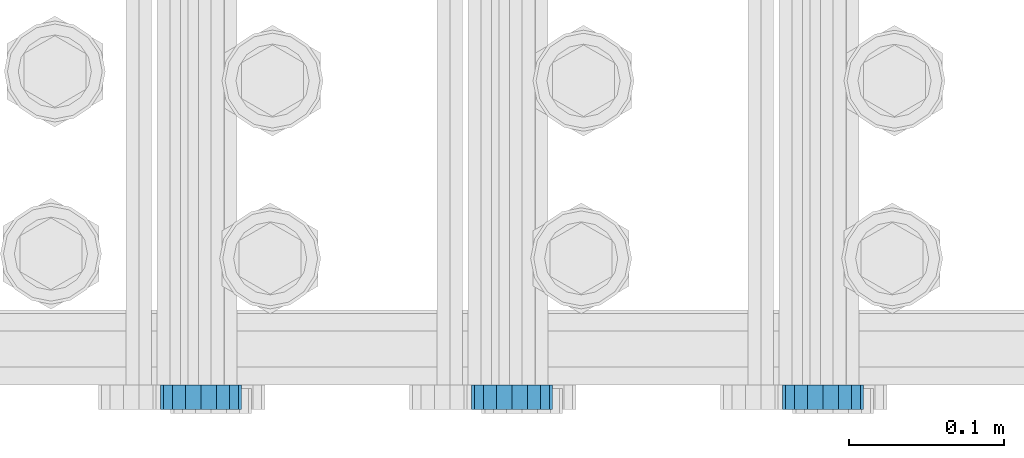
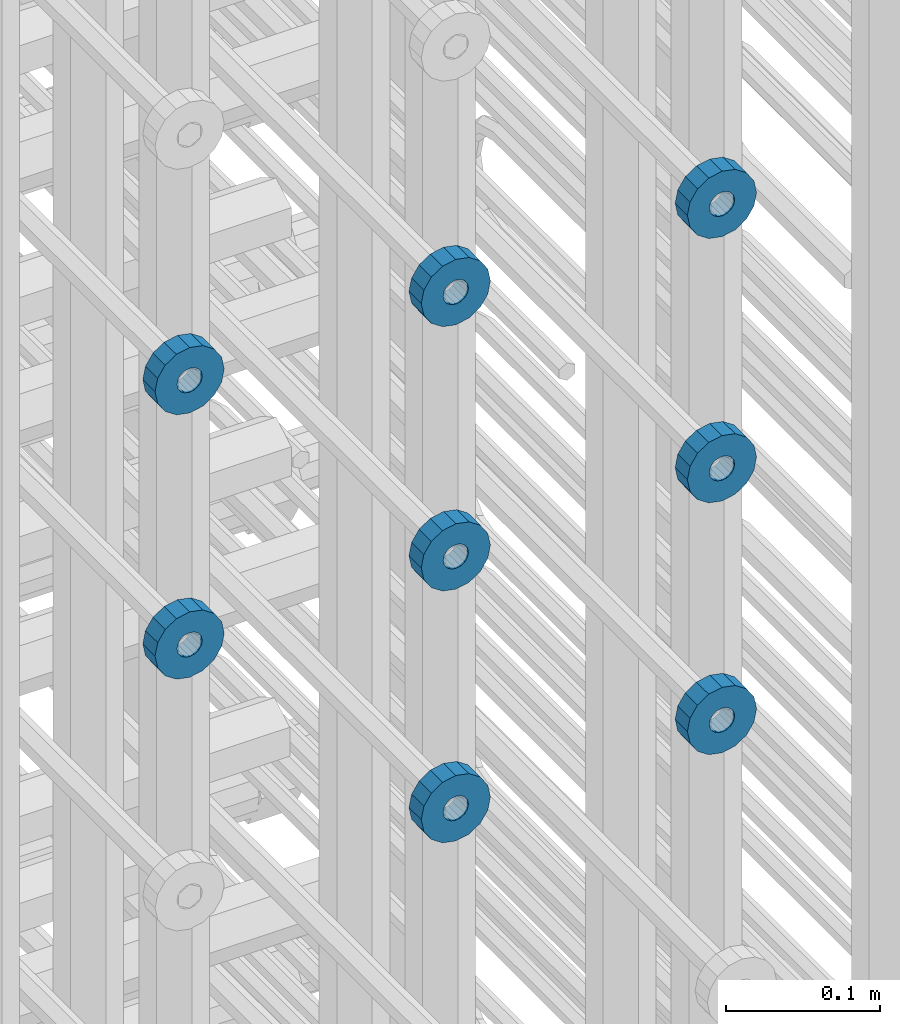
# One storey, part 124 of 177: 8 beams.
"""IFC2X3 building model written with IfcOpenShell, lengths in millimetres."""

from ifc_helpers import new_model, si_unit, frame, origin_with_axes, place, context, subcontext, project, spatial, faceted_brep, material, type_object, element, save


model = new_model("IFC2X3")

# Units and contexts
model_context_1 = context("Model", 3, precision=1e-05, world=origin_with_axes())
model_context_2 = context("Model", 3, precision=1e-05, world=origin_with_axes())
body_context = subcontext(model_context_2, "Body", "Model", "MODEL_VIEW")
ifc_project = project(units=[si_unit("LENGTHUNIT", "METRE", prefix="MILLI"), si_unit("AREAUNIT", "SQUARE_METRE"), si_unit("VOLUMEUNIT", "CUBIC_METRE"), si_unit("MASSUNIT", "GRAM", prefix="KILO"), si_unit("TIMEUNIT", "SECOND"), si_unit("PLANEANGLEUNIT", "RADIAN"), si_unit("SOLIDANGLEUNIT", "STERADIAN"), si_unit("THERMODYNAMICTEMPERATUREUNIT", "DEGREE_CELSIUS"), si_unit("LUMINOUSINTENSITYUNIT", "LUMEN")], contexts=[model_context_1])

# Site, building, storey
site_placement = place(None, origin_with_axes())
site = spatial("IfcSite", under=ifc_project, at=site_placement, CompositionType="ELEMENT")
building_placement = place(site_placement, origin_with_axes())
building = spatial("IfcBuilding", under=site, at=building_placement, Name="Undefined", CompositionType="ELEMENT")
storey_placement = place(building_placement, origin_with_axes())
storey = spatial("IfcBuildingStorey", under=building, at=storey_placement, Name="Undefined", CompositionType="ELEMENT", Elevation=0.0)

# Beams
ifc_material = material(Name="STEEL/Steel_Undefined")
beam_type = type_object("IfcBeamType", PredefinedType="NOTDEFINED")
beam_1_placement = place(storey_placement, frame((2031329.49847313, 6205075.98588607, 21759.9868126721), z_axis=(0.0, 0.0, -1.0), x_axis=(0.0, -1.0, 0.0)))
element("IfcBeam", 1, at=beam_1_placement, inside=storey, type_object=beam_type, material=ifc_material, context=body_context, shape_type="Brep", body=[
    faceted_brep([(0.0, -9.5, 0.0), (0.0, -8.77685555908829, 3.63549260746731), (16.0, -8.77685555908829, 3.63549260746731), (16.0, -9.5, 0.0), (0.0, -6.71751442085952, 6.71751442127061), (16.0, -6.71751442085952, 6.71751442127061), (0.0, -3.63549260701984, 8.77685555885546), (16.0, -3.63549260701984, 8.77685555885546), (-2.02452244836415e-12, 0.0, 9.5), (16.0, 0.0, 9.5), (0.0, 3.63549260701984, 8.77685555885546), (16.0, 3.63549260701984, 8.77685555885546), (0.0, 6.71751442085952, 6.71751442127061), (16.0, 6.71751442085952, 6.71751442127061), (0.0, 8.77685555908829, 3.63549260746731), (16.0, 8.77685555908829, 3.63549260746731), (0.0, 9.5, 0.0), (16.0, 9.5, 0.0), (0.0, 8.77685555908829, -3.63549260746731), (16.0, 8.77685555908829, -3.63549260746731), (0.0, 6.71751442085952, -6.71751442127061), (16.0, 6.71751442085952, -6.71751442127061), (0.0, 3.63549260701984, -8.77685555885546), (16.0, 3.63549260701984, -8.77685555885546), (2.02452244836415e-12, -3.69149155687865e-15, -9.5), (16.0, 0.0, -9.5), (0.0, -3.63549260701984, -8.77685555885546), (16.0, -3.63549260701984, -8.77685555885546), (0.0, -6.71751442085952, -6.71751442127061), (16.0, -6.71751442085952, -6.71751442127061), (0.0, -8.77685555908829, -3.63549260746731), (16.0, -8.77685555908829, -3.63549260746731), (0.0, -26.0, 0.0), (0.0, -24.0208678450435, -9.94976924149159), (16.0, -24.0208678450435, -9.94976924149159), (16.0, -26.0, 0.0), (0.0, -18.3847763109952, -18.3847763108497), (16.0, -18.3847763109952, -18.3847763108497), (0.0, -9.94976924173534, -24.0208678452946), (16.0, -9.94976924173534, -24.0208678452946), (0.0, 0.0, -26.0), (16.0, 0.0, -26.0), (0.0, 9.94976924173534, -24.0208678452946), (16.0, 9.94976924173534, -24.0208678452946), (0.0, 18.3847763109952, -18.3847763108497), (16.0, 18.3847763109952, -18.3847763108497), (0.0, 24.0208678450435, -9.94976924149159), (16.0, 24.0208678450435, -9.94976924149159), (0.0, 26.0, 0.0), (16.0, 26.0, 0.0), (0.0, 24.0208678450435, 9.94976924149159), (16.0, 24.0208678450435, 9.94976924149159), (0.0, 18.3847763109952, 18.3847763108497), (16.0, 18.3847763109952, 18.3847763108497), (0.0, 9.94976924173534, 24.0208678452946), (16.0, 9.94976924173534, 24.0208678452946), (0.0, 0.0, 26.0), (16.0, 0.0, 26.0), (0.0, -9.94976924173534, 24.0208678452946), (16.0, -9.94976924173534, 24.0208678452946), (0.0, -18.3847763109952, 18.3847763108497), (16.0, -18.3847763109952, 18.3847763108497), (0.0, -24.0208678450435, 9.94976924149159), (16.0, -24.0208678450435, 9.94976924149159)], [[[0, 1, 2, 3]], [[1, 4, 5, 2]], [[4, 6, 7, 5]], [[6, 8, 9, 7]], [[8, 10, 11, 9]], [[10, 12, 13, 11]], [[12, 14, 15, 13]], [[14, 16, 17, 15]], [[16, 18, 19, 17]], [[18, 20, 21, 19]], [[20, 22, 23, 21]], [[22, 24, 25, 23]], [[24, 26, 27, 25]], [[26, 28, 29, 27]], [[28, 30, 31, 29]], [[30, 0, 3, 31]], [[32, 33, 34, 35]], [[33, 36, 37, 34]], [[36, 38, 39, 37]], [[38, 40, 41, 39]], [[40, 42, 43, 41]], [[42, 44, 45, 43]], [[44, 46, 47, 45]], [[46, 48, 49, 47]], [[48, 50, 51, 49]], [[50, 52, 53, 51]], [[52, 54, 55, 53]], [[54, 56, 57, 55]], [[56, 58, 59, 57]], [[58, 60, 61, 59]], [[60, 62, 63, 61]], [[62, 32, 35, 63]], [[37, 39, 41, 43, 45, 47, 49, 51, 53, 55, 57, 59, 61, 63, 35, 34], [5, 7, 9, 11, 13, 15, 17, 19, 21, 23, 25, 27, 29, 31, 3, 2]], [[62, 60, 58, 56, 54, 52, 50, 48, 46, 44, 42, 40, 38, 36, 33, 32], [30, 28, 26, 24, 22, 20, 18, 16, 14, 12, 10, 8, 6, 4, 1, 0]]]),
])
beam_2_placement = place(storey_placement, frame((2031129.49847313, 6205075.98588607, 21759.9868126721), z_axis=(0.0, 0.0, -1.0), x_axis=(0.0, -1.0, 0.0)))
element("IfcBeam", 2, at=beam_2_placement, inside=storey, type_object=beam_type, material=ifc_material, context=body_context, shape_type="Brep", body=[
    faceted_brep([(0.0, -9.5, 0.0), (0.0, -8.77685555908829, 3.63549260746731), (16.0, -8.77685555908829, 3.63549260746731), (16.0, -9.5, 0.0), (0.0, -6.71751442085952, 6.71751442127061), (16.0, -6.71751442085952, 6.71751442127061), (0.0, -3.63549260701984, 8.77685555885546), (16.0, -3.63549260701984, 8.77685555885546), (-2.02452244836415e-12, 0.0, 9.5), (16.0, 0.0, 9.5), (0.0, 3.63549260701984, 8.77685555885546), (16.0, 3.63549260701984, 8.77685555885546), (0.0, 6.71751442085952, 6.71751442127061), (16.0, 6.71751442085952, 6.71751442127061), (0.0, 8.77685555908829, 3.63549260746731), (16.0, 8.77685555908829, 3.63549260746731), (0.0, 9.5, 0.0), (16.0, 9.5, 0.0), (0.0, 8.77685555908829, -3.63549260746731), (16.0, 8.77685555908829, -3.63549260746731), (0.0, 6.71751442085952, -6.71751442127061), (16.0, 6.71751442085952, -6.71751442127061), (0.0, 3.63549260701984, -8.77685555885546), (16.0, 3.63549260701984, -8.77685555885546), (2.02452244836415e-12, -3.69149155687865e-15, -9.5), (16.0, 0.0, -9.5), (0.0, -3.63549260701984, -8.77685555885546), (16.0, -3.63549260701984, -8.77685555885546), (0.0, -6.71751442085952, -6.71751442127061), (16.0, -6.71751442085952, -6.71751442127061), (0.0, -8.77685555908829, -3.63549260746731), (16.0, -8.77685555908829, -3.63549260746731), (0.0, -26.0, 0.0), (0.0, -24.0208678450435, -9.94976924149159), (16.0, -24.0208678450435, -9.94976924149159), (16.0, -26.0, 0.0), (0.0, -18.3847763109952, -18.3847763108497), (16.0, -18.3847763109952, -18.3847763108497), (0.0, -9.94976924173534, -24.0208678452946), (16.0, -9.94976924173534, -24.0208678452946), (0.0, 0.0, -26.0), (16.0, 0.0, -26.0), (0.0, 9.94976924173534, -24.0208678452946), (16.0, 9.94976924173534, -24.0208678452946), (0.0, 18.3847763109952, -18.3847763108497), (16.0, 18.3847763109952, -18.3847763108497), (0.0, 24.0208678450435, -9.94976924149159), (16.0, 24.0208678450435, -9.94976924149159), (0.0, 26.0, 0.0), (16.0, 26.0, 0.0), (0.0, 24.0208678450435, 9.94976924149159), (16.0, 24.0208678450435, 9.94976924149159), (0.0, 18.3847763109952, 18.3847763108497), (16.0, 18.3847763109952, 18.3847763108497), (0.0, 9.94976924173534, 24.0208678452946), (16.0, 9.94976924173534, 24.0208678452946), (0.0, 0.0, 26.0), (16.0, 0.0, 26.0), (0.0, -9.94976924173534, 24.0208678452946), (16.0, -9.94976924173534, 24.0208678452946), (0.0, -18.3847763109952, 18.3847763108497), (16.0, -18.3847763109952, 18.3847763108497), (0.0, -24.0208678450435, 9.94976924149159), (16.0, -24.0208678450435, 9.94976924149159)], [[[0, 1, 2, 3]], [[1, 4, 5, 2]], [[4, 6, 7, 5]], [[6, 8, 9, 7]], [[8, 10, 11, 9]], [[10, 12, 13, 11]], [[12, 14, 15, 13]], [[14, 16, 17, 15]], [[16, 18, 19, 17]], [[18, 20, 21, 19]], [[20, 22, 23, 21]], [[22, 24, 25, 23]], [[24, 26, 27, 25]], [[26, 28, 29, 27]], [[28, 30, 31, 29]], [[30, 0, 3, 31]], [[32, 33, 34, 35]], [[33, 36, 37, 34]], [[36, 38, 39, 37]], [[38, 40, 41, 39]], [[40, 42, 43, 41]], [[42, 44, 45, 43]], [[44, 46, 47, 45]], [[46, 48, 49, 47]], [[48, 50, 51, 49]], [[50, 52, 53, 51]], [[52, 54, 55, 53]], [[54, 56, 57, 55]], [[56, 58, 59, 57]], [[58, 60, 61, 59]], [[60, 62, 63, 61]], [[62, 32, 35, 63]], [[37, 39, 41, 43, 45, 47, 49, 51, 53, 55, 57, 59, 61, 63, 35, 34], [5, 7, 9, 11, 13, 15, 17, 19, 21, 23, 25, 27, 29, 31, 3, 2]], [[62, 60, 58, 56, 54, 52, 50, 48, 46, 44, 42, 40, 38, 36, 33, 32], [30, 28, 26, 24, 22, 20, 18, 16, 14, 12, 10, 8, 6, 4, 1, 0]]]),
])
beam_3_placement = place(storey_placement, frame((2030929.49847313, 6205075.98588607, 21759.9868126721), z_axis=(0.0, 0.0, -1.0), x_axis=(0.0, -1.0, 0.0)))
element("IfcBeam", 3, at=beam_3_placement, inside=storey, type_object=beam_type, material=ifc_material, context=body_context, shape_type="Brep", body=[
    faceted_brep([(0.0, -9.5, 0.0), (0.0, -8.77685555908829, 3.63549260746731), (16.0, -8.77685555908829, 3.63549260746731), (16.0, -9.5, 0.0), (0.0, -6.71751442085952, 6.71751442127061), (16.0, -6.71751442085952, 6.71751442127061), (0.0, -3.63549260701984, 8.77685555885546), (16.0, -3.63549260701984, 8.77685555885546), (-2.02452244836415e-12, 0.0, 9.5), (16.0, 0.0, 9.5), (0.0, 3.63549260701984, 8.77685555885546), (16.0, 3.63549260701984, 8.77685555885546), (0.0, 6.71751442085952, 6.71751442127061), (16.0, 6.71751442085952, 6.71751442127061), (0.0, 8.77685555908829, 3.63549260746731), (16.0, 8.77685555908829, 3.63549260746731), (0.0, 9.5, 0.0), (16.0, 9.5, 0.0), (0.0, 8.77685555908829, -3.63549260746731), (16.0, 8.77685555908829, -3.63549260746731), (0.0, 6.71751442085952, -6.71751442127061), (16.0, 6.71751442085952, -6.71751442127061), (0.0, 3.63549260701984, -8.77685555885546), (16.0, 3.63549260701984, -8.77685555885546), (2.02452244836415e-12, -3.69149155687865e-15, -9.5), (16.0, 0.0, -9.5), (0.0, -3.63549260701984, -8.77685555885546), (16.0, -3.63549260701984, -8.77685555885546), (0.0, -6.71751442085952, -6.71751442127061), (16.0, -6.71751442085952, -6.71751442127061), (0.0, -8.77685555908829, -3.63549260746731), (16.0, -8.77685555908829, -3.63549260746731), (0.0, -26.0, 0.0), (0.0, -24.0208678450435, -9.94976924149159), (16.0, -24.0208678450435, -9.94976924149159), (16.0, -26.0, 0.0), (0.0, -18.3847763109952, -18.3847763108497), (16.0, -18.3847763109952, -18.3847763108497), (0.0, -9.94976924173534, -24.0208678452946), (16.0, -9.94976924173534, -24.0208678452946), (0.0, 0.0, -26.0), (16.0, 0.0, -26.0), (0.0, 9.94976924173534, -24.0208678452946), (16.0, 9.94976924173534, -24.0208678452946), (0.0, 18.3847763109952, -18.3847763108497), (16.0, 18.3847763109952, -18.3847763108497), (0.0, 24.0208678450435, -9.94976924149159), (16.0, 24.0208678450435, -9.94976924149159), (0.0, 26.0, 0.0), (16.0, 26.0, 0.0), (0.0, 24.0208678450435, 9.94976924149159), (16.0, 24.0208678450435, 9.94976924149159), (0.0, 18.3847763109952, 18.3847763108497), (16.0, 18.3847763109952, 18.3847763108497), (0.0, 9.94976924173534, 24.0208678452946), (16.0, 9.94976924173534, 24.0208678452946), (0.0, 0.0, 26.0), (16.0, 0.0, 26.0), (0.0, -9.94976924173534, 24.0208678452946), (16.0, -9.94976924173534, 24.0208678452946), (0.0, -18.3847763109952, 18.3847763108497), (16.0, -18.3847763109952, 18.3847763108497), (0.0, -24.0208678450435, 9.94976924149159), (16.0, -24.0208678450435, 9.94976924149159)], [[[0, 1, 2, 3]], [[1, 4, 5, 2]], [[4, 6, 7, 5]], [[6, 8, 9, 7]], [[8, 10, 11, 9]], [[10, 12, 13, 11]], [[12, 14, 15, 13]], [[14, 16, 17, 15]], [[16, 18, 19, 17]], [[18, 20, 21, 19]], [[20, 22, 23, 21]], [[22, 24, 25, 23]], [[24, 26, 27, 25]], [[26, 28, 29, 27]], [[28, 30, 31, 29]], [[30, 0, 3, 31]], [[32, 33, 34, 35]], [[33, 36, 37, 34]], [[36, 38, 39, 37]], [[38, 40, 41, 39]], [[40, 42, 43, 41]], [[42, 44, 45, 43]], [[44, 46, 47, 45]], [[46, 48, 49, 47]], [[48, 50, 51, 49]], [[50, 52, 53, 51]], [[52, 54, 55, 53]], [[54, 56, 57, 55]], [[56, 58, 59, 57]], [[58, 60, 61, 59]], [[60, 62, 63, 61]], [[62, 32, 35, 63]], [[37, 39, 41, 43, 45, 47, 49, 51, 53, 55, 57, 59, 61, 63, 35, 34], [5, 7, 9, 11, 13, 15, 17, 19, 21, 23, 25, 27, 29, 31, 3, 2]], [[62, 60, 58, 56, 54, 52, 50, 48, 46, 44, 42, 40, 38, 36, 33, 32], [30, 28, 26, 24, 22, 20, 18, 16, 14, 12, 10, 8, 6, 4, 1, 0]]]),
])
beam_4_placement = place(storey_placement, frame((2031329.49847313, 6205075.98588592, 21549.9868126721), z_axis=(0.0, 0.0, -1.0), x_axis=(0.0, -1.0, 0.0)))
element("IfcBeam", 4, at=beam_4_placement, inside=storey, type_object=beam_type, material=ifc_material, context=body_context, shape_type="Brep", body=[
    faceted_brep([(0.0, -9.5, 0.0), (0.0, -8.77685555908829, 3.63549260746731), (16.0, -8.77685555908829, 3.63549260746731), (16.0, -9.5, 0.0), (0.0, -6.71751442085952, 6.71751442127061), (16.0, -6.71751442085952, 6.71751442127061), (0.0, -3.63549260701984, 8.77685555885546), (16.0, -3.63549260701984, 8.77685555885546), (-2.02452244836415e-12, 0.0, 9.5), (16.0, 0.0, 9.5), (0.0, 3.63549260701984, 8.77685555885546), (16.0, 3.63549260701984, 8.77685555885546), (0.0, 6.71751442085952, 6.71751442127061), (16.0, 6.71751442085952, 6.71751442127061), (0.0, 8.77685555908829, 3.63549260746731), (16.0, 8.77685555908829, 3.63549260746731), (0.0, 9.5, 0.0), (16.0, 9.5, 0.0), (0.0, 8.77685555908829, -3.63549260746731), (16.0, 8.77685555908829, -3.63549260746731), (0.0, 6.71751442085952, -6.71751442127061), (16.0, 6.71751442085952, -6.71751442127061), (0.0, 3.63549260701984, -8.77685555885546), (16.0, 3.63549260701984, -8.77685555885546), (2.02452244836415e-12, -3.69149155687865e-15, -9.5), (16.0, 0.0, -9.5), (0.0, -3.63549260701984, -8.77685555885546), (16.0, -3.63549260701984, -8.77685555885546), (0.0, -6.71751442085952, -6.71751442127061), (16.0, -6.71751442085952, -6.71751442127061), (0.0, -8.77685555908829, -3.63549260746731), (16.0, -8.77685555908829, -3.63549260746731), (0.0, -26.0, 0.0), (0.0, -24.0208678450435, -9.94976924149159), (16.0, -24.0208678450435, -9.94976924149159), (16.0, -26.0, 0.0), (0.0, -18.3847763109952, -18.3847763108497), (16.0, -18.3847763109952, -18.3847763108497), (0.0, -9.94976924173534, -24.0208678452946), (16.0, -9.94976924173534, -24.0208678452946), (0.0, 0.0, -26.0), (16.0, 0.0, -26.0), (0.0, 9.94976924173534, -24.0208678452946), (16.0, 9.94976924173534, -24.0208678452946), (0.0, 18.3847763109952, -18.3847763108497), (16.0, 18.3847763109952, -18.3847763108497), (0.0, 24.0208678450435, -9.94976924149159), (16.0, 24.0208678450435, -9.94976924149159), (0.0, 26.0, 0.0), (16.0, 26.0, 0.0), (0.0, 24.0208678450435, 9.94976924149159), (16.0, 24.0208678450435, 9.94976924149159), (0.0, 18.3847763109952, 18.3847763108497), (16.0, 18.3847763109952, 18.3847763108497), (0.0, 9.94976924173534, 24.0208678452946), (16.0, 9.94976924173534, 24.0208678452946), (0.0, 0.0, 26.0), (16.0, 0.0, 26.0), (0.0, -9.94976924173534, 24.0208678452946), (16.0, -9.94976924173534, 24.0208678452946), (0.0, -18.3847763109952, 18.3847763108497), (16.0, -18.3847763109952, 18.3847763108497), (0.0, -24.0208678450435, 9.94976924149159), (16.0, -24.0208678450435, 9.94976924149159)], [[[0, 1, 2, 3]], [[1, 4, 5, 2]], [[4, 6, 7, 5]], [[6, 8, 9, 7]], [[8, 10, 11, 9]], [[10, 12, 13, 11]], [[12, 14, 15, 13]], [[14, 16, 17, 15]], [[16, 18, 19, 17]], [[18, 20, 21, 19]], [[20, 22, 23, 21]], [[22, 24, 25, 23]], [[24, 26, 27, 25]], [[26, 28, 29, 27]], [[28, 30, 31, 29]], [[30, 0, 3, 31]], [[32, 33, 34, 35]], [[33, 36, 37, 34]], [[36, 38, 39, 37]], [[38, 40, 41, 39]], [[40, 42, 43, 41]], [[42, 44, 45, 43]], [[44, 46, 47, 45]], [[46, 48, 49, 47]], [[48, 50, 51, 49]], [[50, 52, 53, 51]], [[52, 54, 55, 53]], [[54, 56, 57, 55]], [[56, 58, 59, 57]], [[58, 60, 61, 59]], [[60, 62, 63, 61]], [[62, 32, 35, 63]], [[37, 39, 41, 43, 45, 47, 49, 51, 53, 55, 57, 59, 61, 63, 35, 34], [5, 7, 9, 11, 13, 15, 17, 19, 21, 23, 25, 27, 29, 31, 3, 2]], [[62, 60, 58, 56, 54, 52, 50, 48, 46, 44, 42, 40, 38, 36, 33, 32], [30, 28, 26, 24, 22, 20, 18, 16, 14, 12, 10, 8, 6, 4, 1, 0]]]),
])
beam_5_placement = place(storey_placement, frame((2031129.49847313, 6205075.98588592, 21549.9868126721), z_axis=(0.0, 0.0, -1.0), x_axis=(0.0, -1.0, 0.0)))
element("IfcBeam", 5, at=beam_5_placement, inside=storey, type_object=beam_type, material=ifc_material, context=body_context, shape_type="Brep", body=[
    faceted_brep([(0.0, -9.5, 0.0), (0.0, -8.77685555908829, 3.63549260746731), (16.0, -8.77685555908829, 3.63549260746731), (16.0, -9.5, 0.0), (0.0, -6.71751442085952, 6.71751442127061), (16.0, -6.71751442085952, 6.71751442127061), (0.0, -3.63549260701984, 8.77685555885546), (16.0, -3.63549260701984, 8.77685555885546), (-2.02452244836415e-12, 0.0, 9.5), (16.0, 0.0, 9.5), (0.0, 3.63549260701984, 8.77685555885546), (16.0, 3.63549260701984, 8.77685555885546), (0.0, 6.71751442085952, 6.71751442127061), (16.0, 6.71751442085952, 6.71751442127061), (0.0, 8.77685555908829, 3.63549260746731), (16.0, 8.77685555908829, 3.63549260746731), (0.0, 9.5, 0.0), (16.0, 9.5, 0.0), (0.0, 8.77685555908829, -3.63549260746731), (16.0, 8.77685555908829, -3.63549260746731), (0.0, 6.71751442085952, -6.71751442127061), (16.0, 6.71751442085952, -6.71751442127061), (0.0, 3.63549260701984, -8.77685555885546), (16.0, 3.63549260701984, -8.77685555885546), (2.02452244836415e-12, -3.69149155687865e-15, -9.5), (16.0, 0.0, -9.5), (0.0, -3.63549260701984, -8.77685555885546), (16.0, -3.63549260701984, -8.77685555885546), (0.0, -6.71751442085952, -6.71751442127061), (16.0, -6.71751442085952, -6.71751442127061), (0.0, -8.77685555908829, -3.63549260746731), (16.0, -8.77685555908829, -3.63549260746731), (0.0, -26.0, 0.0), (0.0, -24.0208678450435, -9.94976924149159), (16.0, -24.0208678450435, -9.94976924149159), (16.0, -26.0, 0.0), (0.0, -18.3847763109952, -18.3847763108497), (16.0, -18.3847763109952, -18.3847763108497), (0.0, -9.94976924173534, -24.0208678452946), (16.0, -9.94976924173534, -24.0208678452946), (0.0, 0.0, -26.0), (16.0, 0.0, -26.0), (0.0, 9.94976924173534, -24.0208678452946), (16.0, 9.94976924173534, -24.0208678452946), (0.0, 18.3847763109952, -18.3847763108497), (16.0, 18.3847763109952, -18.3847763108497), (0.0, 24.0208678450435, -9.94976924149159), (16.0, 24.0208678450435, -9.94976924149159), (0.0, 26.0, 0.0), (16.0, 26.0, 0.0), (0.0, 24.0208678450435, 9.94976924149159), (16.0, 24.0208678450435, 9.94976924149159), (0.0, 18.3847763109952, 18.3847763108497), (16.0, 18.3847763109952, 18.3847763108497), (0.0, 9.94976924173534, 24.0208678452946), (16.0, 9.94976924173534, 24.0208678452946), (0.0, 0.0, 26.0), (16.0, 0.0, 26.0), (0.0, -9.94976924173534, 24.0208678452946), (16.0, -9.94976924173534, 24.0208678452946), (0.0, -18.3847763109952, 18.3847763108497), (16.0, -18.3847763109952, 18.3847763108497), (0.0, -24.0208678450435, 9.94976924149159), (16.0, -24.0208678450435, 9.94976924149159)], [[[0, 1, 2, 3]], [[1, 4, 5, 2]], [[4, 6, 7, 5]], [[6, 8, 9, 7]], [[8, 10, 11, 9]], [[10, 12, 13, 11]], [[12, 14, 15, 13]], [[14, 16, 17, 15]], [[16, 18, 19, 17]], [[18, 20, 21, 19]], [[20, 22, 23, 21]], [[22, 24, 25, 23]], [[24, 26, 27, 25]], [[26, 28, 29, 27]], [[28, 30, 31, 29]], [[30, 0, 3, 31]], [[32, 33, 34, 35]], [[33, 36, 37, 34]], [[36, 38, 39, 37]], [[38, 40, 41, 39]], [[40, 42, 43, 41]], [[42, 44, 45, 43]], [[44, 46, 47, 45]], [[46, 48, 49, 47]], [[48, 50, 51, 49]], [[50, 52, 53, 51]], [[52, 54, 55, 53]], [[54, 56, 57, 55]], [[56, 58, 59, 57]], [[58, 60, 61, 59]], [[60, 62, 63, 61]], [[62, 32, 35, 63]], [[37, 39, 41, 43, 45, 47, 49, 51, 53, 55, 57, 59, 61, 63, 35, 34], [5, 7, 9, 11, 13, 15, 17, 19, 21, 23, 25, 27, 29, 31, 3, 2]], [[62, 60, 58, 56, 54, 52, 50, 48, 46, 44, 42, 40, 38, 36, 33, 32], [30, 28, 26, 24, 22, 20, 18, 16, 14, 12, 10, 8, 6, 4, 1, 0]]]),
])
beam_6_placement = place(storey_placement, frame((2030929.49847313, 6205075.98588592, 21549.9868126721), z_axis=(0.0, 0.0, -1.0), x_axis=(0.0, -1.0, 0.0)))
element("IfcBeam", 6, at=beam_6_placement, inside=storey, type_object=beam_type, material=ifc_material, context=body_context, shape_type="Brep", body=[
    faceted_brep([(0.0, -9.5, 0.0), (0.0, -8.77685555908829, 3.63549260746731), (16.0, -8.77685555908829, 3.63549260746731), (16.0, -9.5, 0.0), (0.0, -6.71751442085952, 6.71751442127061), (16.0, -6.71751442085952, 6.71751442127061), (0.0, -3.63549260701984, 8.77685555885546), (16.0, -3.63549260701984, 8.77685555885546), (-2.02452244836415e-12, 0.0, 9.5), (16.0, 0.0, 9.5), (0.0, 3.63549260701984, 8.77685555885546), (16.0, 3.63549260701984, 8.77685555885546), (0.0, 6.71751442085952, 6.71751442127061), (16.0, 6.71751442085952, 6.71751442127061), (0.0, 8.77685555908829, 3.63549260746731), (16.0, 8.77685555908829, 3.63549260746731), (0.0, 9.5, 0.0), (16.0, 9.5, 0.0), (0.0, 8.77685555908829, -3.63549260746731), (16.0, 8.77685555908829, -3.63549260746731), (0.0, 6.71751442085952, -6.71751442127061), (16.0, 6.71751442085952, -6.71751442127061), (0.0, 3.63549260701984, -8.77685555885546), (16.0, 3.63549260701984, -8.77685555885546), (2.02452244836415e-12, -3.69149155687865e-15, -9.5), (16.0, 0.0, -9.5), (0.0, -3.63549260701984, -8.77685555885546), (16.0, -3.63549260701984, -8.77685555885546), (0.0, -6.71751442085952, -6.71751442127061), (16.0, -6.71751442085952, -6.71751442127061), (0.0, -8.77685555908829, -3.63549260746731), (16.0, -8.77685555908829, -3.63549260746731), (0.0, -26.0, 0.0), (0.0, -24.0208678450435, -9.94976924149159), (16.0, -24.0208678450435, -9.94976924149159), (16.0, -26.0, 0.0), (0.0, -18.3847763109952, -18.3847763108497), (16.0, -18.3847763109952, -18.3847763108497), (0.0, -9.94976924173534, -24.0208678452946), (16.0, -9.94976924173534, -24.0208678452946), (0.0, 0.0, -26.0), (16.0, 0.0, -26.0), (0.0, 9.94976924173534, -24.0208678452946), (16.0, 9.94976924173534, -24.0208678452946), (0.0, 18.3847763109952, -18.3847763108497), (16.0, 18.3847763109952, -18.3847763108497), (0.0, 24.0208678450435, -9.94976924149159), (16.0, 24.0208678450435, -9.94976924149159), (0.0, 26.0, 0.0), (16.0, 26.0, 0.0), (0.0, 24.0208678450435, 9.94976924149159), (16.0, 24.0208678450435, 9.94976924149159), (0.0, 18.3847763109952, 18.3847763108497), (16.0, 18.3847763109952, 18.3847763108497), (0.0, 9.94976924173534, 24.0208678452946), (16.0, 9.94976924173534, 24.0208678452946), (0.0, 0.0, 26.0), (16.0, 0.0, 26.0), (0.0, -9.94976924173534, 24.0208678452946), (16.0, -9.94976924173534, 24.0208678452946), (0.0, -18.3847763109952, 18.3847763108497), (16.0, -18.3847763109952, 18.3847763108497), (0.0, -24.0208678450435, 9.94976924149159), (16.0, -24.0208678450435, 9.94976924149159)], [[[0, 1, 2, 3]], [[1, 4, 5, 2]], [[4, 6, 7, 5]], [[6, 8, 9, 7]], [[8, 10, 11, 9]], [[10, 12, 13, 11]], [[12, 14, 15, 13]], [[14, 16, 17, 15]], [[16, 18, 19, 17]], [[18, 20, 21, 19]], [[20, 22, 23, 21]], [[22, 24, 25, 23]], [[24, 26, 27, 25]], [[26, 28, 29, 27]], [[28, 30, 31, 29]], [[30, 0, 3, 31]], [[32, 33, 34, 35]], [[33, 36, 37, 34]], [[36, 38, 39, 37]], [[38, 40, 41, 39]], [[40, 42, 43, 41]], [[42, 44, 45, 43]], [[44, 46, 47, 45]], [[46, 48, 49, 47]], [[48, 50, 51, 49]], [[50, 52, 53, 51]], [[52, 54, 55, 53]], [[54, 56, 57, 55]], [[56, 58, 59, 57]], [[58, 60, 61, 59]], [[60, 62, 63, 61]], [[62, 32, 35, 63]], [[37, 39, 41, 43, 45, 47, 49, 51, 53, 55, 57, 59, 61, 63, 35, 34], [5, 7, 9, 11, 13, 15, 17, 19, 21, 23, 25, 27, 29, 31, 3, 2]], [[62, 60, 58, 56, 54, 52, 50, 48, 46, 44, 42, 40, 38, 36, 33, 32], [30, 28, 26, 24, 22, 20, 18, 16, 14, 12, 10, 8, 6, 4, 1, 0]]]),
])
beam_7_placement = place(storey_placement, frame((2031329.49847313, 6205075.98588576, 21349.9868126721), z_axis=(0.0, 0.0, -1.0), x_axis=(0.0, -1.0, 0.0)))
element("IfcBeam", 7, at=beam_7_placement, inside=storey, type_object=beam_type, material=ifc_material, context=body_context, shape_type="Brep", body=[
    faceted_brep([(0.0, -9.5, 0.0), (0.0, -8.77685555908829, 3.63549260746731), (16.0, -8.77685555908829, 3.63549260746731), (16.0, -9.5, 0.0), (0.0, -6.71751442085952, 6.71751442127061), (16.0, -6.71751442085952, 6.71751442127061), (0.0, -3.63549260701984, 8.77685555885546), (16.0, -3.63549260701984, 8.77685555885546), (-2.02452244836415e-12, 0.0, 9.5), (16.0, 0.0, 9.5), (0.0, 3.63549260701984, 8.77685555885546), (16.0, 3.63549260701984, 8.77685555885546), (0.0, 6.71751442085952, 6.71751442127061), (16.0, 6.71751442085952, 6.71751442127061), (0.0, 8.77685555908829, 3.63549260746731), (16.0, 8.77685555908829, 3.63549260746731), (0.0, 9.5, 0.0), (16.0, 9.5, 0.0), (0.0, 8.77685555908829, -3.63549260746731), (16.0, 8.77685555908829, -3.63549260746731), (0.0, 6.71751442085952, -6.71751442127061), (16.0, 6.71751442085952, -6.71751442127061), (0.0, 3.63549260701984, -8.77685555885546), (16.0, 3.63549260701984, -8.77685555885546), (2.02452244836415e-12, -3.69149155687865e-15, -9.5), (16.0, 0.0, -9.5), (0.0, -3.63549260701984, -8.77685555885546), (16.0, -3.63549260701984, -8.77685555885546), (0.0, -6.71751442085952, -6.71751442127061), (16.0, -6.71751442085952, -6.71751442127061), (0.0, -8.77685555908829, -3.63549260746731), (16.0, -8.77685555908829, -3.63549260746731), (0.0, -26.0, 0.0), (0.0, -24.0208678450435, -9.94976924149159), (16.0, -24.0208678450435, -9.94976924149159), (16.0, -26.0, 0.0), (0.0, -18.3847763109952, -18.3847763108497), (16.0, -18.3847763109952, -18.3847763108497), (0.0, -9.94976924173534, -24.0208678452946), (16.0, -9.94976924173534, -24.0208678452946), (0.0, 0.0, -26.0), (16.0, 0.0, -26.0), (0.0, 9.94976924173534, -24.0208678452946), (16.0, 9.94976924173534, -24.0208678452946), (0.0, 18.3847763109952, -18.3847763108497), (16.0, 18.3847763109952, -18.3847763108497), (0.0, 24.0208678450435, -9.94976924149159), (16.0, 24.0208678450435, -9.94976924149159), (0.0, 26.0, 0.0), (16.0, 26.0, 0.0), (0.0, 24.0208678450435, 9.94976924149159), (16.0, 24.0208678450435, 9.94976924149159), (0.0, 18.3847763109952, 18.3847763108497), (16.0, 18.3847763109952, 18.3847763108497), (0.0, 9.94976924173534, 24.0208678452946), (16.0, 9.94976924173534, 24.0208678452946), (0.0, 0.0, 26.0), (16.0, 0.0, 26.0), (0.0, -9.94976924173534, 24.0208678452946), (16.0, -9.94976924173534, 24.0208678452946), (0.0, -18.3847763109952, 18.3847763108497), (16.0, -18.3847763109952, 18.3847763108497), (0.0, -24.0208678450435, 9.94976924149159), (16.0, -24.0208678450435, 9.94976924149159)], [[[0, 1, 2, 3]], [[1, 4, 5, 2]], [[4, 6, 7, 5]], [[6, 8, 9, 7]], [[8, 10, 11, 9]], [[10, 12, 13, 11]], [[12, 14, 15, 13]], [[14, 16, 17, 15]], [[16, 18, 19, 17]], [[18, 20, 21, 19]], [[20, 22, 23, 21]], [[22, 24, 25, 23]], [[24, 26, 27, 25]], [[26, 28, 29, 27]], [[28, 30, 31, 29]], [[30, 0, 3, 31]], [[32, 33, 34, 35]], [[33, 36, 37, 34]], [[36, 38, 39, 37]], [[38, 40, 41, 39]], [[40, 42, 43, 41]], [[42, 44, 45, 43]], [[44, 46, 47, 45]], [[46, 48, 49, 47]], [[48, 50, 51, 49]], [[50, 52, 53, 51]], [[52, 54, 55, 53]], [[54, 56, 57, 55]], [[56, 58, 59, 57]], [[58, 60, 61, 59]], [[60, 62, 63, 61]], [[62, 32, 35, 63]], [[37, 39, 41, 43, 45, 47, 49, 51, 53, 55, 57, 59, 61, 63, 35, 34], [5, 7, 9, 11, 13, 15, 17, 19, 21, 23, 25, 27, 29, 31, 3, 2]], [[62, 60, 58, 56, 54, 52, 50, 48, 46, 44, 42, 40, 38, 36, 33, 32], [30, 28, 26, 24, 22, 20, 18, 16, 14, 12, 10, 8, 6, 4, 1, 0]]]),
])
beam_8_placement = place(storey_placement, frame((2031129.49847313, 6205075.98588576, 21349.9868126721), z_axis=(0.0, 0.0, -1.0), x_axis=(0.0, -1.0, 0.0)))
element("IfcBeam", 8, at=beam_8_placement, inside=storey, type_object=beam_type, material=ifc_material, context=body_context, shape_type="Brep", body=[
    faceted_brep([(0.0, -9.5, 0.0), (0.0, -8.77685555908829, 3.63549260746731), (16.0, -8.77685555908829, 3.63549260746731), (16.0, -9.5, 0.0), (0.0, -6.71751442085952, 6.71751442127061), (16.0, -6.71751442085952, 6.71751442127061), (0.0, -3.63549260701984, 8.77685555885546), (16.0, -3.63549260701984, 8.77685555885546), (-2.02452244836415e-12, 0.0, 9.5), (16.0, 0.0, 9.5), (0.0, 3.63549260701984, 8.77685555885546), (16.0, 3.63549260701984, 8.77685555885546), (0.0, 6.71751442085952, 6.71751442127061), (16.0, 6.71751442085952, 6.71751442127061), (0.0, 8.77685555908829, 3.63549260746731), (16.0, 8.77685555908829, 3.63549260746731), (0.0, 9.5, 0.0), (16.0, 9.5, 0.0), (0.0, 8.77685555908829, -3.63549260746731), (16.0, 8.77685555908829, -3.63549260746731), (0.0, 6.71751442085952, -6.71751442127061), (16.0, 6.71751442085952, -6.71751442127061), (0.0, 3.63549260701984, -8.77685555885546), (16.0, 3.63549260701984, -8.77685555885546), (2.02452244836415e-12, -3.69149155687865e-15, -9.5), (16.0, 0.0, -9.5), (0.0, -3.63549260701984, -8.77685555885546), (16.0, -3.63549260701984, -8.77685555885546), (0.0, -6.71751442085952, -6.71751442127061), (16.0, -6.71751442085952, -6.71751442127061), (0.0, -8.77685555908829, -3.63549260746731), (16.0, -8.77685555908829, -3.63549260746731), (0.0, -26.0, 0.0), (0.0, -24.0208678450435, -9.94976924149159), (16.0, -24.0208678450435, -9.94976924149159), (16.0, -26.0, 0.0), (0.0, -18.3847763109952, -18.3847763108497), (16.0, -18.3847763109952, -18.3847763108497), (0.0, -9.94976924173534, -24.0208678452946), (16.0, -9.94976924173534, -24.0208678452946), (0.0, 0.0, -26.0), (16.0, 0.0, -26.0), (0.0, 9.94976924173534, -24.0208678452946), (16.0, 9.94976924173534, -24.0208678452946), (0.0, 18.3847763109952, -18.3847763108497), (16.0, 18.3847763109952, -18.3847763108497), (0.0, 24.0208678450435, -9.94976924149159), (16.0, 24.0208678450435, -9.94976924149159), (0.0, 26.0, 0.0), (16.0, 26.0, 0.0), (0.0, 24.0208678450435, 9.94976924149159), (16.0, 24.0208678450435, 9.94976924149159), (0.0, 18.3847763109952, 18.3847763108497), (16.0, 18.3847763109952, 18.3847763108497), (0.0, 9.94976924173534, 24.0208678452946), (16.0, 9.94976924173534, 24.0208678452946), (0.0, 0.0, 26.0), (16.0, 0.0, 26.0), (0.0, -9.94976924173534, 24.0208678452946), (16.0, -9.94976924173534, 24.0208678452946), (0.0, -18.3847763109952, 18.3847763108497), (16.0, -18.3847763109952, 18.3847763108497), (0.0, -24.0208678450435, 9.94976924149159), (16.0, -24.0208678450435, 9.94976924149159)], [[[0, 1, 2, 3]], [[1, 4, 5, 2]], [[4, 6, 7, 5]], [[6, 8, 9, 7]], [[8, 10, 11, 9]], [[10, 12, 13, 11]], [[12, 14, 15, 13]], [[14, 16, 17, 15]], [[16, 18, 19, 17]], [[18, 20, 21, 19]], [[20, 22, 23, 21]], [[22, 24, 25, 23]], [[24, 26, 27, 25]], [[26, 28, 29, 27]], [[28, 30, 31, 29]], [[30, 0, 3, 31]], [[32, 33, 34, 35]], [[33, 36, 37, 34]], [[36, 38, 39, 37]], [[38, 40, 41, 39]], [[40, 42, 43, 41]], [[42, 44, 45, 43]], [[44, 46, 47, 45]], [[46, 48, 49, 47]], [[48, 50, 51, 49]], [[50, 52, 53, 51]], [[52, 54, 55, 53]], [[54, 56, 57, 55]], [[56, 58, 59, 57]], [[58, 60, 61, 59]], [[60, 62, 63, 61]], [[62, 32, 35, 63]], [[37, 39, 41, 43, 45, 47, 49, 51, 53, 55, 57, 59, 61, 63, 35, 34], [5, 7, 9, 11, 13, 15, 17, 19, 21, 23, 25, 27, 29, 31, 3, 2]], [[62, 60, 58, 56, 54, 52, 50, 48, 46, 44, 42, 40, 38, 36, 33, 32], [30, 28, 26, 24, 22, 20, 18, 16, 14, 12, 10, 8, 6, 4, 1, 0]]]),
])

save(model, "model.ifc")
